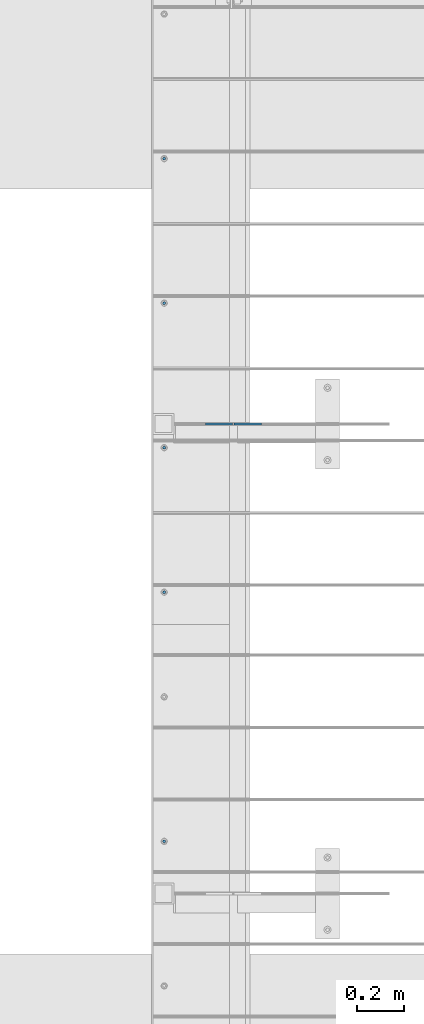
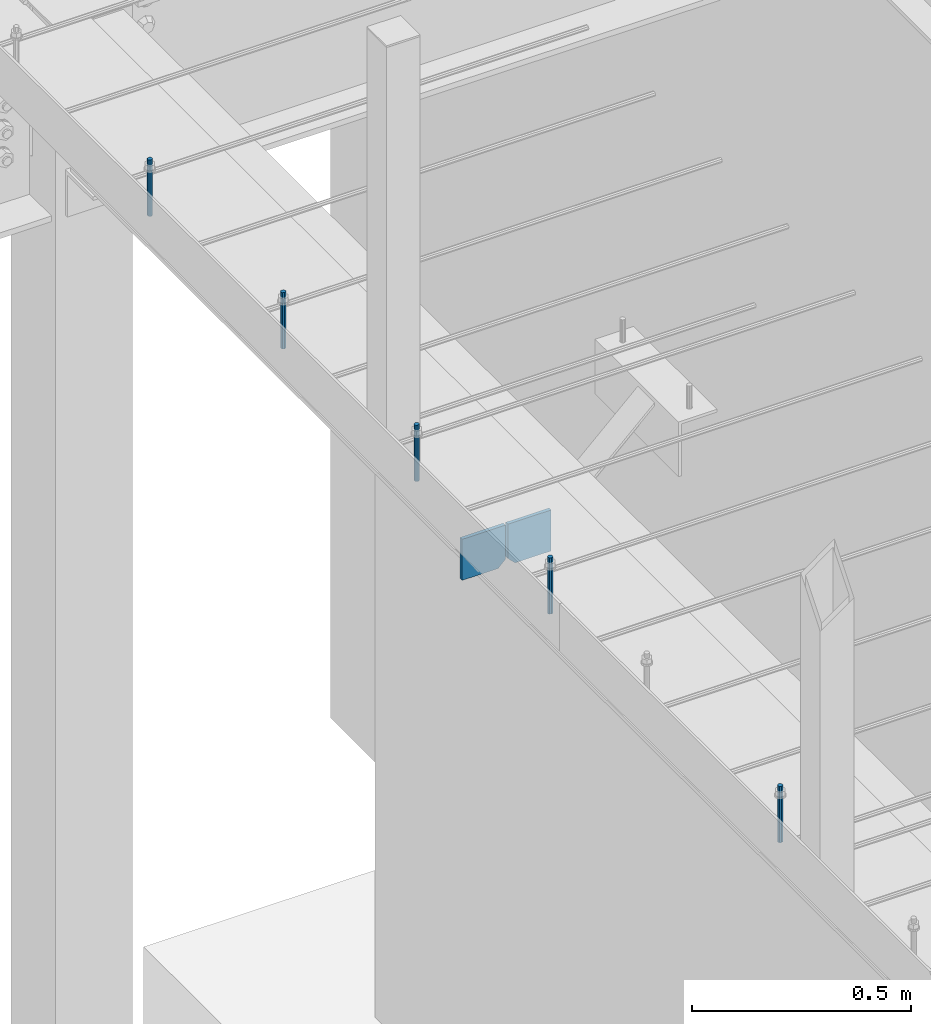
# One storey, part 401 of 1179: 7 columns, 1 element without a shape of its own.
"""IFC2X3 building model written with IfcOpenShell, lengths in millimetres."""

from ifc_helpers import new_model, si_unit, frame, origin_with_axes, place, context, subcontext, project, spatial, faceted_brep, material, type_object, element, aggregate, save


model = new_model("IFC2X3")

# Units and contexts
model_context = context("Model", 3, precision=1e-05, world=origin_with_axes())
body_context = subcontext(model_context, "Body", "Model", "MODEL_VIEW")
ifc_project = project(units=[si_unit("LENGTHUNIT", "METRE", prefix="MILLI"), si_unit("AREAUNIT", "SQUARE_METRE"), si_unit("VOLUMEUNIT", "CUBIC_METRE"), si_unit("MASSUNIT", "GRAM", prefix="KILO"), si_unit("TIMEUNIT", "SECOND"), si_unit("PLANEANGLEUNIT", "RADIAN"), si_unit("SOLIDANGLEUNIT", "STERADIAN"), si_unit("THERMODYNAMICTEMPERATUREUNIT", "DEGREE_CELSIUS"), si_unit("LUMINOUSINTENSITYUNIT", "LUMEN")], contexts=[model_context])

# Site, building, storey
site_placement = place(None, origin_with_axes())
site = spatial("IfcSite", under=ifc_project, at=site_placement, CompositionType="ELEMENT")
building_placement = place(site_placement, origin_with_axes())
building = spatial("IfcBuilding", under=site, at=building_placement, Name="Undefined", CompositionType="ELEMENT")
storey_placement = place(building_placement, origin_with_axes())
storey = spatial("IfcBuildingStorey", under=building, at=storey_placement, Name="Undefined", CompositionType="ELEMENT", Elevation=0.0)

# Assembly, columns
assembly_placement = place(storey_placement, origin_with_axes())
assembly = element("IfcElementAssembly", 1, at=assembly_placement, inside=storey, Name="BEAM", AssemblyPlace="NOTDEFINED", PredefinedType="RIGID_FRAME")
ifc_material_1 = material(Name="STEEL/A36")
column_type_1 = type_object("IfcColumnType", PredefinedType="NOTDEFINED")
column_1_placement = place(assembly_placement, frame((16398.875, 9499.6, 3709.9875), z_axis=(1.0, 0.0, 0.0), x_axis=(0.0, 0.0, 1.0)))
column_1 = element("IfcColumn", 2, at=column_1_placement, type_object=column_type_1, material=ifc_material_1, Name="PLATE", context=body_context, shape_type="Brep", body=[
    faceted_brep([(19.0500000000002, 4.76250000000073, 57.1500000000015), (0.0, 4.76250000000073, 38.0999999999985), (0.0, -4.76250000000073, 38.0999999999985), (19.0500000000002, -4.76250000000073, 57.1500000000015), (114.300000000001, 4.76250000000073, 57.1500000000015), (114.300000000001, 4.76250000000073, -57.1500000000015), (0.0, 4.76250000000073, -57.1500000000015), (114.300000000001, -4.76250000000073, 57.1500000000015), (0.0, -4.76250000000073, -57.1500000000015), (114.300000000001, -4.76250000000073, -57.1500000000015)], [[[0, 1, 2, 3]], [[4, 5, 6, 1, 0]], [[7, 4, 0, 3]], [[8, 9, 7, 3, 2]], [[8, 6, 5, 9]], [[7, 9, 5, 4]], [[6, 8, 2, 1]]]),
])
column_2_placement = place(assembly_placement, frame((16519.525, 9499.6, 3709.9875), z_axis=(-1.0, 0.0, 0.0), x_axis=(0.0, 0.0, 1.0)))
column_2 = element("IfcColumn", 3, at=column_2_placement, type_object=column_type_1, material=ifc_material_1, Name="PLATE", context=body_context, shape_type="Brep", body=[
    faceted_brep([(19.0500000000002, 4.76250000000073, 57.1500000000015), (0.0, 4.76250000000073, 38.0999999999985), (0.0, -4.76250000000073, 38.0999999999985), (19.0500000000002, -4.76250000000073, 57.1500000000015), (114.300000000001, 4.76250000000073, 57.1500000000015), (114.300000000001, 4.76250000000073, -57.1500000000015), (0.0, 4.76250000000073, -57.1500000000015), (114.300000000001, -4.76250000000073, 57.1500000000015), (0.0, -4.76250000000073, -57.1500000000015), (114.300000000001, -4.76250000000073, -57.1500000000015)], [[[0, 1, 2, 3]], [[4, 5, 6, 1, 0]], [[7, 4, 0, 3]], [[8, 9, 7, 3, 2]], [[8, 6, 5, 9]], [[7, 9, 5, 4]], [[6, 8, 2, 1]]]),
])
ifc_material_2 = material(Name="STEEL/A307")
column_type_2 = type_object("IfcColumnType", PredefinedType="NOTDEFINED")
column_3_placement = place(assembly_placement, frame((16167.1, 10618.788, 4108.45), z_axis=(0.0, 1.0, 0.0), x_axis=(0.0, 0.0, 1.0)))
column_3 = element("IfcColumn", 4, at=column_3_placement, type_object=column_type_2, material=ifc_material_2, Name="THREADED ROD", context=body_context, shape_type="Brep", body=[
    faceted_brep([(0.0, -6.34999999999854, 0.0), (0.0, -4.49012806053361, -4.49012806053452), (157.162499999999, -4.49012806053361, -4.49012806053361), (157.162499999999, -6.34999999999854, 0.0), (0.0, 0.0, -6.34999999999991), (157.162499999999, 0.0, -6.34999999999854), (0.0, 4.49012806053361, -4.49012806053452), (157.162499999999, 4.49012806053361, -4.49012806053361), (0.0, 6.34999999999854, 0.0), (157.162499999999, 6.34999999999854, 0.0), (0.0, 4.49012806053361, 4.49012806053452), (157.162499999999, 4.49012806053361, 4.49012806053361), (0.0, 0.0, 6.34999999999991), (157.162499999999, 0.0, 6.34999999999854), (0.0, -4.49012806053361, 4.49012806053452), (157.162499999999, -4.49012806053361, 4.49012806053361)], [[[0, 1, 2, 3]], [[1, 4, 5, 2]], [[4, 6, 7, 5]], [[6, 8, 9, 7]], [[8, 10, 11, 9]], [[10, 12, 13, 11]], [[12, 14, 15, 13]], [[14, 0, 3, 15]], [[5, 7, 9, 11, 13, 15, 3, 2]], [[14, 12, 10, 8, 6, 4, 1, 0]]]),
])
column_4_placement = place(assembly_placement, frame((16167.1, 10009.188, 4108.45), z_axis=(0.0, 1.0, 0.0), x_axis=(0.0, 0.0, 1.0)))
column_4 = element("IfcColumn", 5, at=column_4_placement, type_object=column_type_2, material=ifc_material_2, Name="THREADED ROD", context=body_context, shape_type="Brep", body=[
    faceted_brep([(0.0, -6.34999999999854, 0.0), (0.0, -4.49012806053361, -4.49012806053452), (157.162499999999, -4.49012806053361, -4.49012806053361), (157.162499999999, -6.34999999999854, 0.0), (0.0, 0.0, -6.34999999999991), (157.162499999999, 0.0, -6.34999999999854), (0.0, 4.49012806053361, -4.49012806053452), (157.162499999999, 4.49012806053361, -4.49012806053361), (0.0, 6.34999999999854, 0.0), (157.162499999999, 6.34999999999854, 0.0), (0.0, 4.49012806053361, 4.49012806053452), (157.162499999999, 4.49012806053361, 4.49012806053361), (0.0, 0.0, 6.34999999999991), (157.162499999999, 0.0, 6.34999999999854), (0.0, -4.49012806053361, 4.49012806053452), (157.162499999999, -4.49012806053361, 4.49012806053361)], [[[0, 1, 2, 3]], [[1, 4, 5, 2]], [[4, 6, 7, 5]], [[6, 8, 9, 7]], [[8, 10, 11, 9]], [[10, 12, 13, 11]], [[12, 14, 15, 13]], [[14, 0, 3, 15]], [[5, 7, 9, 11, 13, 15, 3, 2]], [[14, 12, 10, 8, 6, 4, 1, 0]]]),
])
column_5_placement = place(assembly_placement, frame((16167.1, 9399.588, 4108.45), z_axis=(0.0, 1.0, 0.0), x_axis=(0.0, 0.0, 1.0)))
column_5 = element("IfcColumn", 6, at=column_5_placement, type_object=column_type_2, material=ifc_material_2, Name="THREADED ROD", context=body_context, shape_type="Brep", body=[
    faceted_brep([(0.0, -6.34999999999854, 0.0), (0.0, -4.49012806053361, -4.49012806053452), (157.162499999999, -4.49012806053361, -4.49012806053361), (157.162499999999, -6.34999999999854, 0.0), (0.0, 0.0, -6.34999999999991), (157.162499999999, 0.0, -6.34999999999854), (0.0, 4.49012806053361, -4.49012806053452), (157.162499999999, 4.49012806053361, -4.49012806053361), (0.0, 6.34999999999854, 0.0), (157.162499999999, 6.34999999999854, 0.0), (0.0, 4.49012806053361, 4.49012806053452), (157.162499999999, 4.49012806053361, 4.49012806053361), (0.0, 0.0, 6.34999999999991), (157.162499999999, 0.0, 6.34999999999854), (0.0, -4.49012806053361, 4.49012806053452), (157.162499999999, -4.49012806053361, 4.49012806053361)], [[[0, 1, 2, 3]], [[1, 4, 5, 2]], [[4, 6, 7, 5]], [[6, 8, 9, 7]], [[8, 10, 11, 9]], [[10, 12, 13, 11]], [[12, 14, 15, 13]], [[14, 0, 3, 15]], [[5, 7, 9, 11, 13, 15, 3, 2]], [[14, 12, 10, 8, 6, 4, 1, 0]]]),
])
column_6_placement = place(assembly_placement, frame((16167.1, 8789.988, 4108.45), z_axis=(0.0, 1.0, 0.0), x_axis=(0.0, 0.0, 1.0)))
column_6 = element("IfcColumn", 7, at=column_6_placement, type_object=column_type_2, material=ifc_material_2, Name="THREADED ROD", context=body_context, shape_type="Brep", body=[
    faceted_brep([(0.0, -6.34999999999854, 0.0), (0.0, -4.49012806053361, -4.49012806053452), (157.162499999999, -4.49012806053361, -4.49012806053361), (157.162499999999, -6.34999999999854, 0.0), (0.0, 0.0, -6.34999999999991), (157.162499999999, 0.0, -6.34999999999854), (0.0, 4.49012806053361, -4.49012806053452), (157.162499999999, 4.49012806053361, -4.49012806053361), (0.0, 6.34999999999854, 0.0), (157.162499999999, 6.34999999999854, 0.0), (0.0, 4.49012806053361, 4.49012806053452), (157.162499999999, 4.49012806053361, 4.49012806053361), (0.0, 0.0, 6.34999999999991), (157.162499999999, 0.0, 6.34999999999854), (0.0, -4.49012806053361, 4.49012806053452), (157.162499999999, -4.49012806053361, 4.49012806053361)], [[[0, 1, 2, 3]], [[1, 4, 5, 2]], [[4, 6, 7, 5]], [[6, 8, 9, 7]], [[8, 10, 11, 9]], [[10, 12, 13, 11]], [[12, 14, 15, 13]], [[14, 0, 3, 15]], [[5, 7, 9, 11, 13, 15, 3, 2]], [[14, 12, 10, 8, 6, 4, 1, 0]]]),
])
column_7_placement = place(assembly_placement, frame((16167.1, 7739.0625, 4108.45), z_axis=(0.0, 1.0, 0.0), x_axis=(0.0, 0.0, 1.0)))
column_7 = element("IfcColumn", 8, at=column_7_placement, type_object=column_type_2, material=ifc_material_2, Name="THREADED ROD", context=body_context, shape_type="Brep", body=[
    faceted_brep([(0.0, -6.34999999999854, 0.0), (0.0, -4.49012806053361, -4.49012806053452), (157.162499999999, -4.49012806053361, -4.49012806053361), (157.162499999999, -6.34999999999854, 0.0), (0.0, 0.0, -6.34999999999991), (157.162499999999, 0.0, -6.34999999999854), (0.0, 4.49012806053361, -4.49012806053452), (157.162499999999, 4.49012806053361, -4.49012806053361), (0.0, 6.34999999999854, 0.0), (157.162499999999, 6.34999999999854, 0.0), (0.0, 4.49012806053361, 4.49012806053452), (157.162499999999, 4.49012806053361, 4.49012806053361), (0.0, 0.0, 6.34999999999991), (157.162499999999, 0.0, 6.34999999999854), (0.0, -4.49012806053361, 4.49012806053452), (157.162499999999, -4.49012806053361, 4.49012806053361)], [[[0, 1, 2, 3]], [[1, 4, 5, 2]], [[4, 6, 7, 5]], [[6, 8, 9, 7]], [[8, 10, 11, 9]], [[10, 12, 13, 11]], [[12, 14, 15, 13]], [[14, 0, 3, 15]], [[5, 7, 9, 11, 13, 15, 3, 2]], [[14, 12, 10, 8, 6, 4, 1, 0]]]),
])
aggregate(assembly, [column_3, column_4, column_5, column_6, column_7, column_1, column_2])

save(model, "model.ifc")
